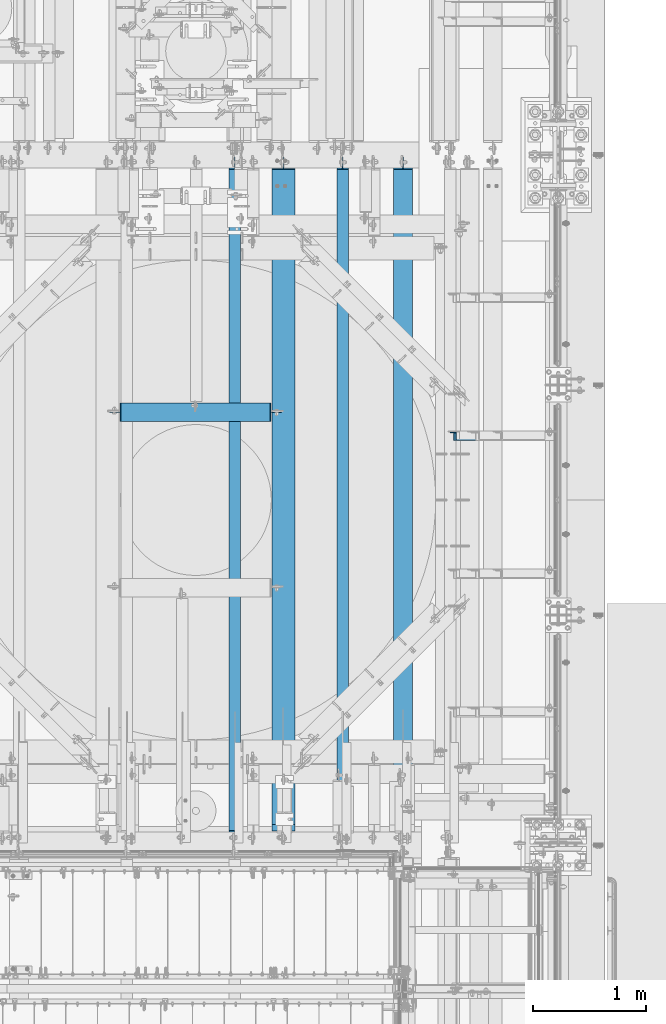
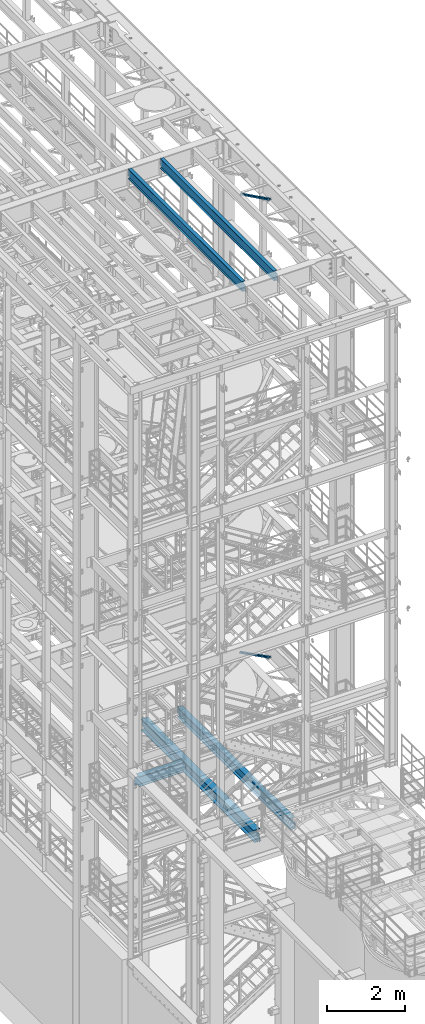
# One storey, part 1012 of 1876: 5 beams, 2 members, 7 elements without a shape of their own.
"""IFC2X3 building model written with IfcOpenShell, lengths in millimetres."""

from ifc_helpers import new_model, si_unit, frame, origin_with_axes, place, context, subcontext, project, spatial, faceted_brep, material, type_object, element, aggregate, save


model = new_model("IFC2X3")

# Units and contexts
model_context = context("Model", 3, precision=1e-05, world=origin_with_axes())
body_context = subcontext(model_context, "Body", "Model", "MODEL_VIEW")
ifc_project = project(units=[si_unit("LENGTHUNIT", "METRE", prefix="MILLI"), si_unit("AREAUNIT", "SQUARE_METRE"), si_unit("VOLUMEUNIT", "CUBIC_METRE"), si_unit("MASSUNIT", "GRAM", prefix="KILO"), si_unit("TIMEUNIT", "SECOND"), si_unit("PLANEANGLEUNIT", "RADIAN"), si_unit("SOLIDANGLEUNIT", "STERADIAN"), si_unit("THERMODYNAMICTEMPERATUREUNIT", "DEGREE_CELSIUS"), si_unit("LUMINOUSINTENSITYUNIT", "LUMEN")], contexts=[model_context])

# Site, building, storey
site_placement = place(None, origin_with_axes())
site = spatial("IfcSite", under=ifc_project, at=site_placement, CompositionType="ELEMENT")
building_placement = place(site_placement, origin_with_axes())
building = spatial("IfcBuilding", under=site, at=building_placement, Name="Undefined", CompositionType="ELEMENT")
storey_placement = place(building_placement, origin_with_axes())
storey = spatial("IfcBuildingStorey", under=building, at=storey_placement, Name="Undefined", CompositionType="ELEMENT", Elevation=0.0)

# Assembly, member
assembly_1_placement = place(storey_placement, origin_with_axes())
assembly_1 = element("IfcElementAssembly", 1, at=assembly_1_placement, inside=storey, AssemblyPlace="NOTDEFINED", PredefinedType="RIGID_FRAME")
ifc_material_1 = material(Name="STEEL/A36")
member_type = type_object("IfcMemberType", Name="L3X3X3/8", PredefinedType="NOTDEFINED")
member_1_placement = place(assembly_1_placement, frame((6618.98281309327, -962.025000000003, 8122.54466495056), z_axis=(0.0, -1.0, 0.0), x_axis=(0.882670061850832, 0.0, -0.469993150920573)))
member_1 = element("IfcMember", 2, at=member_1_placement, type_object=member_type, material=ifc_material_1, ObjectType="L3X3X3/8", context=body_context, shape_type="Brep", body=[
    faceted_brep([(70.0788597189262, 38.1000000000258, -38.1), (70.0788597189262, 38.1000000000258, 38.1), (1091.31003699859, 38.1000000003387, 38.1), (1091.31003699859, 38.1000000003387, -38.1), (70.0788597189253, 28.5750000000244, 38.1), (1091.31003699859, 28.5750000003391, 38.1), (70.0788597189253, 28.5750000000244, -28.575), (1091.31003699859, 28.5750000003391, -28.575), (70.0788597189262, -38.0999999999822, -28.575), (1091.31003699859, -38.0999999996675, -28.575), (70.0788597189262, -38.0999999999822, -38.1), (1091.31003699859, -38.0999999996675, -38.1)], [[[0, 1, 2, 3]], [[1, 4, 5, 2]], [[4, 6, 7, 5]], [[6, 8, 9, 7]], [[8, 10, 11, 9]], [[10, 0, 3, 11]], [[5, 7, 9, 11, 3, 2]], [[10, 8, 6, 4, 1, 0]]]),
])
aggregate(assembly_1, [member_1])

assembly_2_placement = place(storey_placement, origin_with_axes())
assembly_2 = element("IfcElementAssembly", 3, at=assembly_2_placement, inside=storey, AssemblyPlace="NOTDEFINED", PredefinedType="RIGID_FRAME")
member_2_placement = place(assembly_2_placement, frame((6649.22451200435, -962.025, 22521.7692276093), z_axis=(0.0, -1.0, 0.0), x_axis=(0.877448093107094, 0.0, -0.479671600058544)))
member_2 = element("IfcMember", 4, at=member_2_placement, type_object=member_type, material=ifc_material_1, ObjectType="L3X3X3/8", context=body_context, shape_type="Brep", body=[
    faceted_brep([(59.7482362440578, 38.0999999998749, -38.0999999999999), (59.7482362440578, 38.0999999998749, 38.0999999999999), (1062.91900040893, 38.0999999984488, 38.0999999999999), (1062.91900040893, 38.0999999984488, -38.0999999999999), (59.7482362440696, 28.5749999998843, 38.0999999999999), (1062.91900040895, 28.5749999984582, 38.0999999999999), (59.7482362440696, 28.5749999998843, -28.5749999999998), (1062.91900040895, 28.5749999984582, -28.5749999999998), (59.7482362441442, -38.1000000000495, -28.5749999999998), (1062.91900040902, -38.1000000014719, -28.5749999999998), (59.7482362441442, -38.1000000000495, -38.0999999999999), (1062.91900040902, -38.1000000014719, -38.0999999999999)], [[[0, 1, 2, 3]], [[1, 4, 5, 2]], [[4, 6, 7, 5]], [[6, 8, 9, 7]], [[8, 10, 11, 9]], [[10, 0, 3, 11]], [[5, 7, 9, 11, 3, 2]], [[10, 8, 6, 4, 1, 0]]]),
])
aggregate(assembly_2, [member_2])

# Assembly, beam
assembly_3_placement = place(storey_placement, origin_with_axes())
assembly_3 = element("IfcElementAssembly", 5, at=assembly_3_placement, inside=storey, Name="BEAM", AssemblyPlace="NOTDEFINED", PredefinedType="RIGID_FRAME")
ifc_material_2 = material(Name="STEEL/A992")
beam_type_1 = type_object("IfcBeamType", Name="W12X16", PredefinedType="NOTDEFINED")
beam_1_placement = place(assembly_3_placement, frame((5715.0, -4572.0, 22402.8), z_axis=(0.0, 0.0, 1.0), x_axis=(0.0, 1.0, 0.0)))
beam_1 = element("IfcBeam", 6, at=beam_1_placement, type_object=beam_type_1, material=ifc_material_2, Name="BEAM", ObjectType="W12X16", context=body_context, shape_type="Brep", body=[
    faceted_brep([(19.84375, -3.17499999999995, -126.999999999996), (19.84375, 3.17499999999995, -126.999999999996), (102.393750190735, 3.17500000000018, -127.000000000001), (102.393750190735, -3.17500000000018, -127.000000000001), (107.25382970878, 3.17500000000018, -127.966729922588), (107.25382970878, -3.17500000000018, -127.966729922588), (111.374006176934, 3.17500000000018, -130.719743823067), (111.374006176934, -3.17500000000018, -130.719743823067), (114.127020077412, 3.17500000000018, -134.839920291221), (114.127020077412, -3.17500000000018, -134.839920291221), (115.09375, -3.17500000000018, -139.699999809266), (115.09375, 3.17500000000018, -139.699999809266), (115.09375, 3.17500000000018, -146.05), (115.09375, 50.8000000000002, -146.05), (115.09375, 50.8000000000002, -152.4), (115.09375, -50.8000000000002, -152.4), (115.09375, -50.8000000000002, -146.05), (115.09375, -3.17500000000018, -146.05), (127.79375, 3.17500000000018, 146.05), (127.79375, 50.8000000000002, 146.05), (5968.20625, 50.8, 146.05), (5968.20625, 3.17499999999995, 146.05), (115.093750190735, -3.17500000000018, 114.299999999999), (115.093750190735, 3.17500000000018, 114.299999999999), (19.84375, 3.17500000000018, 114.299999999999), (19.84375, -3.17500000000018, 114.299999999999), (119.95382970878, -3.17500000000018, 115.266729922587), (119.95382970878, 3.17500000000018, 115.266729922587), (124.074006176934, -3.17500000000018, 118.019743823065), (124.074006176934, 3.17500000000018, 118.019743823065), (126.827020077412, -3.17500000000018, 122.139920291219), (126.827020077412, 3.17500000000018, 122.139920291219), (127.79375, -3.17500000000018, 126.999999809264), (127.79375, 3.17500000000018, 126.999999809264), (127.79375, 50.8000000000002, 152.4), (127.79375, -50.8000000000002, 152.4), (5968.20625, -50.8, 152.4), (5968.20625, 50.8, 152.4), (127.79375, -50.8000000000002, 146.05), (5968.20625, -50.8, 146.05), (127.79375, -3.17500000000018, 146.05), (5968.20625, -3.17499999999995, 146.05), (5968.20625, -3.17499999999995, 126.999999809264), (5968.20625, 3.17499999999995, 126.999999809264), (5969.17297992259, -3.17499999999995, 122.139920291219), (5969.17297992259, 3.17499999999995, 122.139920291219), (5971.92599382307, -3.17499999999995, 118.019743823065), (5971.92599382307, 3.17499999999995, 118.019743823065), (5976.04617029122, -3.17499999999995, 115.266729922587), (5976.04617029122, 3.17499999999995, 115.266729922587), (5980.90624980927, -3.17499999999995, 114.299999999999), (5980.90624980927, 3.17499999999995, 114.299999999999), (6076.15625, -3.17499999999995, 114.299999999999), (6076.15625, 3.17499999999995, 114.299999999999), (6076.15625, -3.17499999999995, -126.999999999996), (6076.15625, 3.17499999999995, -126.999999999996), (5993.60624980927, -3.17499999999995, -127.000000000001), (5993.60624980927, 3.17499999999995, -127.000000000001), (5988.74617029122, -3.17499999999995, -127.966729922588), (5988.74617029122, 3.17499999999995, -127.966729922588), (5984.62599382307, -3.17499999999995, -130.719743823067), (5984.62599382307, 3.17499999999995, -130.719743823067), (5981.87297992259, -3.17499999999995, -134.839920291221), (5981.87297992259, 3.17499999999995, -134.839920291221), (5980.90625, -3.17499999999995, -139.699999809266), (5980.90625, 3.17499999999995, -139.699999809266), (5980.90625, -3.17499999999995, -146.05), (5980.90625, -50.8, -146.05), (5980.90625, -50.8, -152.4), (5980.90625, 50.8, -152.4), (5980.90625, 50.8, -146.05), (5980.90625, 3.17499999999995, -146.05)], [[[0, 1, 2, 3]], [[3, 2, 4, 5]], [[5, 4, 6, 7]], [[7, 6, 8, 9]], [[10, 11, 12, 13, 14, 15, 16, 17]], [[9, 8, 11, 10]], [[18, 19, 20, 21]], [[22, 23, 24, 25]], [[26, 27, 23, 22]], [[28, 29, 27, 26]], [[30, 31, 29, 28]], [[32, 33, 31, 30]], [[34, 35, 36, 37]], [[35, 38, 39, 36]], [[38, 40, 41, 39]], [[35, 34, 19, 18, 33, 32, 40, 38]], [[19, 34, 37, 20]], [[36, 39, 41, 42, 43, 21, 20, 37]], [[44, 45, 43, 42]], [[46, 47, 45, 44]], [[48, 49, 47, 46]], [[50, 51, 49, 48]], [[52, 53, 51, 50]], [[53, 52, 54, 55]], [[54, 56, 57, 55]], [[58, 59, 57, 56]], [[60, 61, 59, 58]], [[62, 63, 61, 60]], [[64, 65, 63, 62]], [[66, 67, 68, 69, 70, 71, 65, 64]], [[17, 16, 67, 66]], [[16, 15, 68, 67]], [[15, 14, 69, 68]], [[14, 13, 70, 69]], [[13, 12, 71, 70]], [[59, 61, 63, 65, 71, 12, 11, 8, 6, 4, 2, 1, 24, 23, 27, 29, 31, 33, 18, 21, 43, 45, 47, 49, 51, 53, 55, 57]], [[25, 24, 1, 0]], [[52, 50, 48, 46, 44, 42, 41, 40, 32, 30, 28, 26, 22, 25, 0, 3, 5, 7, 9, 10, 17, 66, 64, 62, 60, 58, 56, 54]]]),
])
aggregate(assembly_3, [beam_1])

assembly_4_placement = place(storey_placement, origin_with_axes())
assembly_4 = element("IfcElementAssembly", 7, at=assembly_4_placement, inside=storey, Name="BEAM", AssemblyPlace="NOTDEFINED", PredefinedType="RIGID_FRAME")
beam_2_placement = place(assembly_4_placement, frame((4762.5, -4572.0, 22402.8), z_axis=(0.0, 0.0, 1.0), x_axis=(0.0, 1.0, 0.0)))
beam_2 = element("IfcBeam", 8, at=beam_2_placement, type_object=beam_type_1, material=ifc_material_2, Name="BEAM", ObjectType="W12X16", context=body_context, shape_type="Brep", body=[
    faceted_brep([(19.84375, -3.17499999999995, -126.999999999996), (19.84375, 3.17499999999995, -126.999999999996), (102.393750190735, 3.17500000000018, -127.000000000001), (102.393750190735, -3.17500000000018, -127.000000000001), (107.25382970878, 3.17500000000018, -127.966729922588), (107.25382970878, -3.17500000000018, -127.966729922588), (111.374006176934, 3.17500000000018, -130.719743823067), (111.374006176934, -3.17500000000018, -130.719743823067), (114.127020077412, 3.17500000000018, -134.839920291221), (114.127020077412, -3.17500000000018, -134.839920291221), (115.09375, -3.17500000000018, -139.699999809266), (115.09375, 3.17500000000018, -139.699999809266), (115.09375, 3.17500000000018, -146.05), (115.09375, 50.8000000000002, -146.05), (115.09375, 50.8000000000002, -152.4), (115.09375, -50.8000000000002, -152.4), (115.09375, -50.8000000000002, -146.05), (115.09375, -3.17500000000018, -146.05), (127.79375, 3.17500000000018, 146.05), (127.79375, 50.8000000000002, 146.05), (5968.20625, 50.8, 146.05), (5968.20625, 3.17499999999995, 146.05), (115.093750190735, -3.17500000000018, 114.299999999999), (115.093750190735, 3.17500000000018, 114.299999999999), (19.84375, 3.17500000000018, 114.299999999999), (19.84375, -3.17500000000018, 114.299999999999), (119.95382970878, -3.17500000000018, 115.266729922587), (119.95382970878, 3.17500000000018, 115.266729922587), (124.074006176934, -3.17500000000018, 118.019743823065), (124.074006176934, 3.17500000000018, 118.019743823065), (126.827020077412, -3.17500000000018, 122.139920291219), (126.827020077412, 3.17500000000018, 122.139920291219), (127.79375, -3.17500000000018, 126.999999809264), (127.79375, 3.17500000000018, 126.999999809264), (127.79375, 50.8000000000002, 152.4), (127.79375, -50.8000000000002, 152.4), (5968.20625, -50.8, 152.4), (5968.20625, 50.8, 152.4), (127.79375, -50.8000000000002, 146.05), (5968.20625, -50.8, 146.05), (127.79375, -3.17500000000018, 146.05), (5968.20625, -3.17499999999995, 146.05), (5968.20625, -3.17499999999995, 126.999999809264), (5968.20625, 3.17499999999995, 126.999999809264), (5969.17297992259, -3.17499999999995, 122.139920291219), (5969.17297992259, 3.17499999999995, 122.139920291219), (5971.92599382307, -3.17499999999995, 118.019743823065), (5971.92599382307, 3.17499999999995, 118.019743823065), (5976.04617029122, -3.17499999999995, 115.266729922587), (5976.04617029122, 3.17499999999995, 115.266729922587), (5980.90624980927, -3.17499999999995, 114.299999999999), (5980.90624980927, 3.17499999999995, 114.299999999999), (6076.15625, -3.17499999999995, 114.299999999999), (6076.15625, 3.17499999999995, 114.299999999999), (6076.15625, -3.17499999999995, -126.999999999996), (6076.15625, 3.17499999999995, -126.999999999996), (5993.60624980927, -3.17499999999995, -127.000000000001), (5993.60624980927, 3.17499999999995, -127.000000000001), (5988.74617029122, -3.17499999999995, -127.966729922588), (5988.74617029122, 3.17499999999995, -127.966729922588), (5984.62599382307, -3.17499999999995, -130.719743823067), (5984.62599382307, 3.17499999999995, -130.719743823067), (5981.87297992259, -3.17499999999995, -134.839920291221), (5981.87297992259, 3.17499999999995, -134.839920291221), (5980.90625, -3.17499999999995, -139.699999809266), (5980.90625, 3.17499999999995, -139.699999809266), (5980.90625, -3.17499999999995, -146.05), (5980.90625, -50.8, -146.05), (5980.90625, -50.8, -152.4), (5980.90625, 50.8, -152.4), (5980.90625, 50.8, -146.05), (5980.90625, 3.17499999999995, -146.05)], [[[0, 1, 2, 3]], [[3, 2, 4, 5]], [[5, 4, 6, 7]], [[7, 6, 8, 9]], [[10, 11, 12, 13, 14, 15, 16, 17]], [[9, 8, 11, 10]], [[18, 19, 20, 21]], [[22, 23, 24, 25]], [[26, 27, 23, 22]], [[28, 29, 27, 26]], [[30, 31, 29, 28]], [[32, 33, 31, 30]], [[34, 35, 36, 37]], [[35, 38, 39, 36]], [[38, 40, 41, 39]], [[35, 34, 19, 18, 33, 32, 40, 38]], [[19, 34, 37, 20]], [[36, 39, 41, 42, 43, 21, 20, 37]], [[44, 45, 43, 42]], [[46, 47, 45, 44]], [[48, 49, 47, 46]], [[50, 51, 49, 48]], [[52, 53, 51, 50]], [[53, 52, 54, 55]], [[54, 56, 57, 55]], [[58, 59, 57, 56]], [[60, 61, 59, 58]], [[62, 63, 61, 60]], [[64, 65, 63, 62]], [[66, 67, 68, 69, 70, 71, 65, 64]], [[17, 16, 67, 66]], [[16, 15, 68, 67]], [[15, 14, 69, 68]], [[14, 13, 70, 69]], [[13, 12, 71, 70]], [[59, 61, 63, 65, 71, 12, 11, 8, 6, 4, 2, 1, 24, 23, 27, 29, 31, 33, 18, 21, 43, 45, 47, 49, 51, 53, 55, 57]], [[25, 24, 1, 0]], [[52, 50, 48, 46, 44, 42, 41, 40, 32, 30, 28, 26, 22, 25, 0, 3, 5, 7, 9, 10, 17, 66, 64, 62, 60, 58, 56, 54]]]),
])
aggregate(assembly_4, [beam_2])

assembly_5_placement = place(storey_placement, origin_with_axes())
assembly_5 = element("IfcElementAssembly", 9, at=assembly_5_placement, inside=storey, Name="BEAM", AssemblyPlace="NOTDEFINED", PredefinedType="RIGID_FRAME")
beam_type_2 = type_object("IfcBeamType", Name="W12X30", PredefinedType="NOTDEFINED")
beam_3_placement = place(assembly_5_placement, frame((3587.75, -749.3, 4973.6375), z_axis=(0.0, 0.0, 1.0), x_axis=(1.0, 0.0, 0.0)))
beam_3 = element("IfcBeam", 10, at=beam_3_placement, type_object=beam_type_2, material=ifc_material_2, Name="BEAM", ObjectType="W12X30", context=body_context, shape_type="Brep", body=[
    faceted_brep([(67.4687500000018, -3.17500000000018, -131.7625), (67.4687500000018, 3.17500000000018, -131.7625), (150.018750190737, 3.17500000000018, -131.7625), (150.018750190737, -3.17500000000018, -131.7625), (154.878829708782, 3.17500000000018, -132.729229922587), (154.878829708782, -3.17500000000018, -132.729229922587), (158.999006176936, 3.17500000000018, -135.482243823066), (158.999006176936, -3.17500000000018, -135.482243823066), (161.752020077414, 3.17500000000018, -139.602420291219), (161.752020077414, -3.17500000000018, -139.602420291219), (162.718750000002, -3.17500000000018, -144.462499809265), (162.718750000002, 3.17500000000018, -144.462499809265), (162.718750000002, 3.17500000000018, -146.05), (162.718750000002, 82.5500000000002, -146.05), (162.718750000002, 82.5500000000002, -157.1625), (162.718750000002, -82.5500000000002, -157.1625), (162.718750000002, -82.5500000000002, -146.05), (162.718750000002, -3.17500000000018, -146.05), (1488.28125, 82.5500000000002, 146.05), (1488.28125, 3.17500000000018, 146.05), (169.068750000002, 3.17500000000018, 146.05), (169.068750000002, 82.5500000000002, 146.05), (156.368750190737, -3.17500000000018, 125.4125), (156.368750190737, 3.17500000000018, 125.4125), (67.4687500000018, 3.17500000000018, 125.4125), (67.4687500000018, -3.17500000000018, 125.4125), (161.228829708782, -3.17500000000018, 126.379229922588), (161.228829708782, 3.17500000000018, 126.379229922588), (165.349006176936, -3.17500000000018, 129.132243823066), (165.349006176936, 3.17500000000018, 129.132243823066), (168.102020077414, -3.17500000000018, 133.25242029122), (168.102020077414, 3.17500000000018, 133.25242029122), (169.068750000002, -3.17500000000018, 138.112499809266), (169.068750000002, 3.17500000000018, 138.112499809266), (1488.28125, -82.5500000000002, 157.1625), (1488.28125, 82.5500000000002, 157.1625), (169.068750000002, 82.5500000000002, 157.1625), (169.068750000002, -82.5500000000002, 157.1625), (1488.28125, -82.5500000000002, 146.05), (169.068750000002, -82.5500000000002, 146.05), (1488.28125, -3.17500000000018, 146.05), (169.068750000002, -3.17500000000018, 146.05), (1488.28125, -3.17500000000018, 138.112499809266), (1488.28125, 3.17500000000018, 138.112499809266), (1489.24797992259, -3.17500000000018, 133.25242029122), (1489.24797992259, 3.17500000000018, 133.25242029122), (1492.00099382306, -3.17500000000018, 129.132243823066), (1492.00099382306, 3.17500000000018, 129.132243823066), (1496.12117029122, -3.17500000000018, 126.379229922588), (1496.12117029122, 3.17500000000018, 126.379229922588), (1500.98124980926, -3.17500000000018, 125.4125), (1500.98124980926, 3.17500000000018, 125.4125), (1589.88125, -3.17500000000018, 125.4125), (1589.88125, 3.17500000000018, 125.4125), (1589.88125, -3.17500000000018, -131.7625), (1589.88125, 3.17500000000018, -131.7625), (1507.33124980926, -3.17500000000018, -131.7625), (1507.33124980926, 3.17500000000018, -131.7625), (1502.47117029122, -3.17500000000018, -132.729229922587), (1502.47117029122, 3.17500000000018, -132.729229922587), (1498.35099382306, -3.17500000000018, -135.482243823066), (1498.35099382306, 3.17500000000018, -135.482243823066), (1495.59797992259, -3.17500000000018, -139.602420291219), (1495.59797992259, 3.17500000000018, -139.602420291219), (1494.63125, -3.17500000000018, -144.462499809265), (1494.63125, 3.17500000000018, -144.462499809265), (1494.63125, -3.17500000000018, -146.05), (1494.63125, -82.5500000000002, -146.05), (1494.63125, -82.5500000000002, -157.1625), (1494.63125, 82.5500000000002, -157.1625), (1494.63125, 82.5500000000002, -146.05), (1494.63125, 3.17500000000018, -146.05)], [[[0, 1, 2, 3]], [[3, 2, 4, 5]], [[5, 4, 6, 7]], [[7, 6, 8, 9]], [[10, 11, 12, 13, 14, 15, 16, 17]], [[9, 8, 11, 10]], [[18, 19, 20, 21]], [[22, 23, 24, 25]], [[26, 27, 23, 22]], [[28, 29, 27, 26]], [[30, 31, 29, 28]], [[32, 33, 31, 30]], [[34, 35, 36, 37]], [[38, 34, 37, 39]], [[40, 38, 39, 41]], [[37, 36, 21, 20, 33, 32, 41, 39]], [[35, 18, 21, 36]], [[34, 38, 40, 42, 43, 19, 18, 35]], [[44, 45, 43, 42]], [[46, 47, 45, 44]], [[48, 49, 47, 46]], [[50, 51, 49, 48]], [[52, 53, 51, 50]], [[53, 52, 54, 55]], [[54, 56, 57, 55]], [[58, 59, 57, 56]], [[60, 61, 59, 58]], [[62, 63, 61, 60]], [[64, 65, 63, 62]], [[66, 67, 68, 69, 70, 71, 65, 64]], [[67, 66, 17, 16]], [[68, 67, 16, 15]], [[69, 68, 15, 14]], [[70, 69, 14, 13]], [[71, 70, 13, 12]], [[6, 4, 2, 1, 24, 23, 27, 29, 31, 33, 20, 19, 43, 45, 47, 49, 51, 53, 55, 57, 59, 61, 63, 65, 71, 12, 11, 8]], [[25, 24, 1, 0]], [[66, 64, 62, 60, 58, 56, 54, 52, 50, 48, 46, 44, 42, 40, 41, 32, 30, 28, 26, 22, 25, 0, 3, 5, 7, 9, 10, 17]]]),
])
aggregate(assembly_5, [beam_3])

assembly_6_placement = place(storey_placement, origin_with_axes())
assembly_6 = element("IfcElementAssembly", 11, at=assembly_6_placement, inside=storey, Name="BEAM", AssemblyPlace="NOTDEFINED", PredefinedType="RIGID_FRAME")
beam_4_placement = place(assembly_6_placement, frame((6248.4, -4572.0, 4973.6375), z_axis=(0.0, 0.0, 1.0), x_axis=(0.0, 1.0, 0.0)))
beam_4 = element("IfcBeam", 12, at=beam_4_placement, type_object=beam_type_2, material=ifc_material_2, Name="BEAM", ObjectType="W12X30", context=body_context, shape_type="Brep", body=[
    faceted_brep([(23.0187500000002, -3.17500000000018, -131.762499999999), (23.0187500000002, 3.17500000000018, -131.762499999999), (105.568750190733, 3.17500000000018, -131.762499999999), (105.568750190733, -3.17500000000018, -131.762499999999), (110.428829708779, 3.17500000000018, -132.729229922586), (110.428829708779, -3.17500000000018, -132.729229922586), (114.549006176932, 3.17500000000018, -135.482243823065), (114.549006176932, -3.17500000000018, -135.482243823065), (117.302020077411, 3.17500000000018, -139.602420291219), (117.302020077411, -3.17500000000018, -139.602420291219), (118.268749999998, -3.17500000000018, -144.462499809264), (118.268749999998, 3.17500000000018, -144.462499809264), (118.268749999998, 3.17500008940715, -146.05), (118.268749999998, 82.5500000000002, -146.05), (118.268749999998, 82.5500000000002, -157.1625), (118.268749999998, -82.5500000000002, -157.1625), (118.268749999998, -82.5500000000002, -146.05), (118.268749999998, -3.17499999999995, -146.05), (5968.20624911051, 82.55, 146.049999999999), (5968.20625, 3.17499999999995, 146.05), (181.768749999998, 3.17499999999995, 146.05), (181.768749999998, 82.5500000000002, 146.05), (169.068750190733, -3.17500000000018, 106.362500000001), (169.068750190733, 3.17500000000018, 106.362500000001), (23.0187500000002, 3.17500000000018, 106.362500000001), (23.0187500000002, -3.17500000000018, 106.362500000001), (173.928829708779, -3.17500000000018, 107.329229922589), (173.928829708779, 3.17500000000018, 107.329229922589), (178.049006176932, -3.17500000000018, 110.082243823067), (178.049006176932, 3.17500000000018, 110.082243823067), (180.802020077411, -3.17500000000018, 114.202420291221), (180.802020077411, 3.17500000000018, 114.202420291221), (181.768749999998, -3.17500000000018, 119.062499809266), (181.768749999998, 3.17500000000018, 119.062499809266), (5968.20624911051, -82.55, 157.162499999999), (5968.20624911051, 82.55, 157.162499999999), (181.768749999998, 82.5500000000002, 157.1625), (181.768749999998, -82.5500000000002, 157.1625), (5968.20624911051, -82.55, 146.049999999999), (181.768749999998, -82.5500000000002, 146.05), (5968.20625, -3.17499999999995, 146.05), (181.768749999998, -3.17499999999995, 146.05), (5968.20624911051, -3.17499999999995, 131.762499809269), (5968.20624911051, 3.17499999999995, 131.762499809269), (5969.17297903309, -3.17499999999995, 126.902420291222), (5969.17297903309, 3.17499999999995, 126.902420291222), (5971.92599293357, -3.17499999999995, 122.782243823069), (5971.92599293357, 3.17499999999995, 122.782243823069), (5976.04616940172, -3.17499999999995, 120.029229922591), (5976.04616940172, 3.17499999999995, 120.029229922591), (5980.90624891977, -3.17499999999995, 119.062500000004), (5980.90624891977, 3.17499999999995, 119.062500000004), (6076.15624911051, -3.17499999999995, 119.062500000004), (6076.15624911051, 3.17499999999995, 119.062500000004), (6076.15625, -3.17500000000018, -131.762499999993), (6076.15625, 3.17500000000018, -131.762499999993), (5993.60624980927, -3.17500000000018, -131.762500000001), (5993.60624980927, 3.17500000000018, -131.762500000001), (5988.74617029122, -3.17500000000018, -132.729229922588), (5988.74617029122, 3.17500000000018, -132.729229922588), (5984.62599382307, -3.17500000000018, -135.482243823067), (5984.62599382307, 3.17500000000018, -135.482243823067), (5981.87297992259, -3.17500000000018, -139.60242029122), (5981.87297992259, 3.17500000000018, -139.60242029122), (5980.90625, -3.17500000000018, -144.462499809266), (5980.90625, 3.17500000000018, -144.462499809266), (5980.90625, -3.17499999999995, -146.05), (5980.90625, -82.5500000000002, -146.049999999999), (5980.90625, -82.5500000000002, -157.1625), (5980.90625, 82.5500000000002, -157.1625), (5980.90625, 82.5500000000002, -146.049999999999), (5980.90625, 3.17499999999995, -146.05)], [[[0, 1, 2, 3]], [[3, 2, 4, 5]], [[5, 4, 6, 7]], [[7, 6, 8, 9]], [[10, 11, 12, 13, 14, 15, 16, 17]], [[9, 8, 11, 10]], [[18, 19, 20, 21]], [[22, 23, 24, 25]], [[26, 27, 23, 22]], [[28, 29, 27, 26]], [[30, 31, 29, 28]], [[32, 33, 31, 30]], [[34, 35, 36, 37]], [[38, 34, 37, 39]], [[40, 38, 39, 41]], [[37, 36, 21, 20, 33, 32, 41, 39]], [[35, 18, 21, 36]], [[34, 38, 40, 42, 43, 19, 18, 35]], [[44, 45, 43, 42]], [[46, 47, 45, 44]], [[48, 49, 47, 46]], [[50, 51, 49, 48]], [[52, 53, 51, 50]], [[53, 52, 54, 55]], [[54, 56, 57, 55]], [[58, 59, 57, 56]], [[60, 61, 59, 58]], [[62, 63, 61, 60]], [[64, 65, 63, 62]], [[66, 67, 68, 69, 70, 71, 65, 64]], [[67, 66, 17, 16]], [[68, 67, 16, 15]], [[69, 68, 15, 14]], [[70, 69, 14, 13]], [[71, 70, 13, 12]], [[6, 4, 2, 1, 24, 23, 27, 29, 31, 33, 20, 19, 43, 45, 47, 49, 51, 53, 55, 57, 59, 61, 63, 65, 71, 12, 11, 8]], [[25, 24, 1, 0]], [[66, 64, 62, 60, 58, 56, 54, 52, 50, 48, 46, 44, 42, 40, 41, 32, 30, 28, 26, 22, 25, 0, 3, 5, 7, 9, 10, 17]]]),
])
aggregate(assembly_6, [beam_4])

assembly_7_placement = place(storey_placement, origin_with_axes())
assembly_7 = element("IfcElementAssembly", 13, at=assembly_7_placement, inside=storey, Name="BEAM", AssemblyPlace="NOTDEFINED", PredefinedType="RIGID_FRAME")
beam_type_3 = type_object("IfcBeamType", Name="W14X48", PredefinedType="NOTDEFINED")
beam_5_placement = place(assembly_7_placement, frame((5194.3, -4572.0, 4956.175), z_axis=(0.0, 0.0, 1.0), x_axis=(0.0, 1.0, 0.0)))
beam_5 = element("IfcBeam", 14, at=beam_5_placement, type_object=beam_type_3, material=ifc_material_2, Name="BEAM", ObjectType="W14X48", context=body_context, shape_type="Brep", body=[
    faceted_brep([(23.0187500000002, -3.96875, -142.874999999999), (23.0187500000002, 3.96875, -142.874999999999), (111.918750190734, 3.96875, -142.874999999999), (111.918750190734, -3.96875, -142.874999999999), (116.778829708779, 3.96875, -143.841729922587), (116.778829708779, -3.96875, -143.841729922587), (120.899006176933, 3.96875, -146.594743823065), (120.899006176933, -3.96875, -146.594743823065), (123.652020077411, 3.96875, -150.714920291219), (123.652020077411, -3.96875, -150.714920291219), (124.618749999999, -3.96875, -155.574999809264), (124.618749999999, 3.96875, -155.574999809264), (124.618749999999, 3.96875, -158.75), (124.618749999999, 101.6, -158.75), (124.618749999999, 101.6, -174.625), (124.618749999999, -101.6, -174.625), (124.618749999999, -101.6, -158.75), (124.618749999999, -3.96875, -158.75), (5968.20625, 101.6, 158.75), (5968.20625, 3.96875, 158.75), (181.768749999998, 3.96875, 158.75), (181.768749999998, 101.6, 158.75), (169.068750190733, -3.96875, 123.825000000001), (169.068750190733, 3.96875, 123.825000000001), (23.0187500000002, 3.96875, 123.825000000001), (23.0187500000002, -3.96875, 123.825000000001), (173.928829708779, -3.96875, 124.791729922588), (173.928829708779, 3.96875, 124.791729922588), (178.049006176932, -3.96875, 127.544743823067), (178.049006176932, 3.96875, 127.544743823067), (180.802020077411, -3.96875, 131.66492029122), (180.802020077411, 3.96875, 131.66492029122), (181.768749999998, -3.96875, 136.524999809266), (181.768749999998, 3.96875, 136.524999809266), (5968.20625, -101.6, 174.625), (5968.20625, 101.6, 174.625), (181.768749999998, 101.6, 174.625), (181.768749999998, -101.6, 174.625), (5968.20625, -101.6, 158.75), (181.768749999998, -101.6, 158.75), (5968.20625, -3.96875, 158.75), (181.768749999998, -3.96875, 158.75), (5968.20625, -3.96875, 149.224999809264), (5968.20625, 3.96875, 149.224999809264), (5969.17297992259, -3.96875, 144.364920291218), (5969.17297992259, 3.96875, 144.364920291218), (5971.92599382307, -3.96875, 140.244743823065), (5971.92599382307, 3.96875, 140.244743823065), (5976.04617029122, -3.96875, 137.491729922586), (5976.04617029122, 3.96875, 137.491729922586), (5980.90624980927, -3.96875, 136.524999999999), (5980.90624980927, 3.96875, 136.524999999999), (6076.15625, -3.96875, 136.525), (6076.15625, 3.96875, 136.525), (6076.15625, -3.96875, -142.875), (6076.15625, 3.96875, -142.875), (5987.25624980927, -3.96875, -142.875000000001), (5987.25624980927, 3.96875, -142.875000000001), (5982.39617029122, -3.96875, -143.841729922588), (5982.39617029122, 3.96875, -143.841729922588), (5978.27599382307, -3.96875, -146.594743823067), (5978.27599382307, 3.96875, -146.594743823067), (5975.52297992259, -3.96875, -150.714920291221), (5975.52297992259, 3.96875, -150.714920291221), (5974.55625, -3.96875, -155.574999809266), (5974.55625, 3.96875, -155.574999809266), (5974.55625, -3.96875, -158.75), (5974.55625, -101.6, -158.75), (5974.55625, -101.6, -174.625), (5974.55625, 101.6, -174.625), (5974.55625, 101.6, -158.75), (5974.55625, 3.96875, -158.75)], [[[0, 1, 2, 3]], [[3, 2, 4, 5]], [[5, 4, 6, 7]], [[7, 6, 8, 9]], [[10, 11, 12, 13, 14, 15, 16, 17]], [[9, 8, 11, 10]], [[18, 19, 20, 21]], [[22, 23, 24, 25]], [[26, 27, 23, 22]], [[28, 29, 27, 26]], [[30, 31, 29, 28]], [[32, 33, 31, 30]], [[34, 35, 36, 37]], [[38, 34, 37, 39]], [[40, 38, 39, 41]], [[37, 36, 21, 20, 33, 32, 41, 39]], [[35, 18, 21, 36]], [[34, 38, 40, 42, 43, 19, 18, 35]], [[44, 45, 43, 42]], [[46, 47, 45, 44]], [[48, 49, 47, 46]], [[50, 51, 49, 48]], [[52, 53, 51, 50]], [[53, 52, 54, 55]], [[54, 56, 57, 55]], [[58, 59, 57, 56]], [[60, 61, 59, 58]], [[62, 63, 61, 60]], [[64, 65, 63, 62]], [[66, 67, 68, 69, 70, 71, 65, 64]], [[67, 66, 17, 16]], [[68, 67, 16, 15]], [[69, 68, 15, 14]], [[70, 69, 14, 13]], [[71, 70, 13, 12]], [[6, 4, 2, 1, 24, 23, 27, 29, 31, 33, 20, 19, 43, 45, 47, 49, 51, 53, 55, 57, 59, 61, 63, 65, 71, 12, 11, 8]], [[25, 24, 1, 0]], [[66, 64, 62, 60, 58, 56, 54, 52, 50, 48, 46, 44, 42, 40, 41, 32, 30, 28, 26, 22, 25, 0, 3, 5, 7, 9, 10, 17]]]),
])
aggregate(assembly_7, [beam_5])

save(model, "model.ifc")
